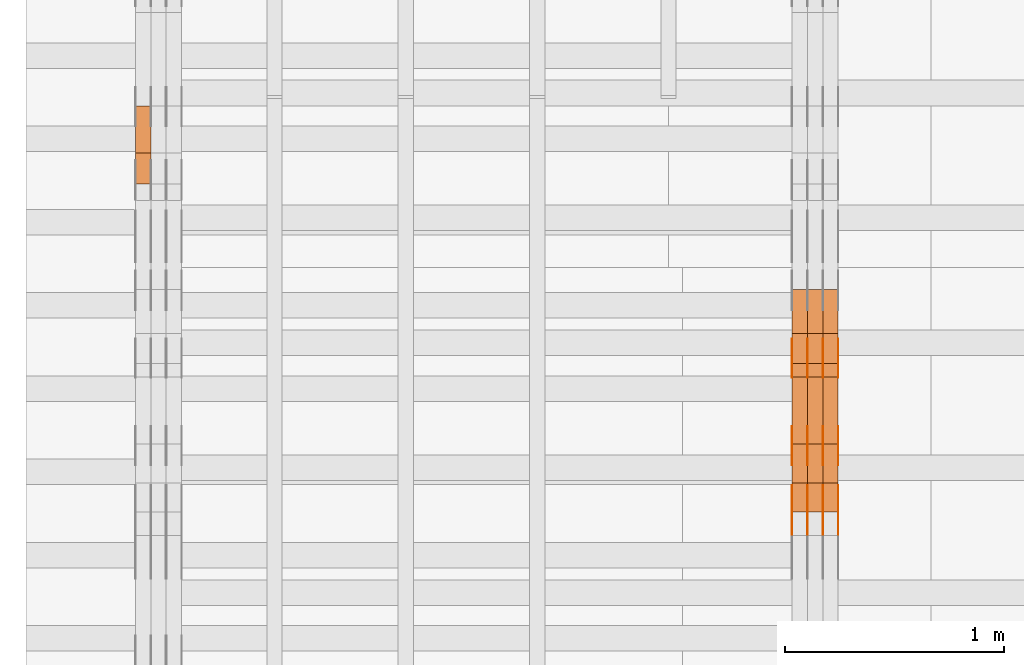
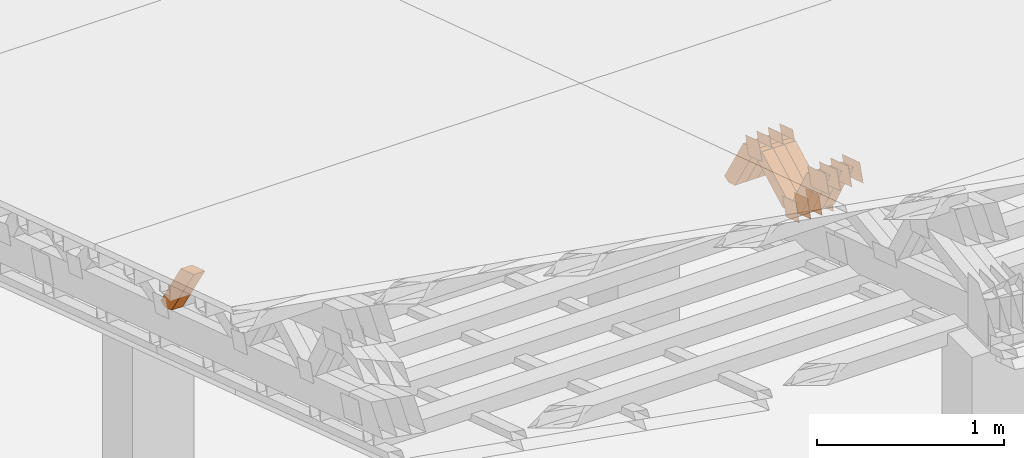
# One storey, part 172 of 385: 28 proxies.
"""IFC2X3 building model written with IfcOpenShell, lengths in millimetres."""

from ifc_helpers import new_model, entity, si_unit, converted_unit, derived_unit, direction, frame, origin, place, context, subcontext, project, spatial, polyline, outline, extrude, source, transform, mapped, material, type_object, type_shapes, element, save


model = new_model("IFC2X3")

# Units and contexts
model_context = context("Model", 3, precision=0.01, world=origin(), true_north=direction((6.12303176911189e-17, 1.0)))
body_context = subcontext(model_context, "Body", "Model", "MODEL_VIEW")
ifc_project = project(units=[si_unit("LENGTHUNIT", "METRE", prefix="MILLI"), si_unit("AREAUNIT", "SQUARE_METRE"), si_unit("VOLUMEUNIT", "CUBIC_METRE"), converted_unit("PLANEANGLEUNIT", "DEGREE", entity("IfcRatioMeasure", 0.0174532925199433), si_unit("PLANEANGLEUNIT", "RADIAN"), dimensions=[0, 0, 0, 0, 0, 0, 0]), si_unit("MASSUNIT", "GRAM", prefix="KILO"), derived_unit("MASSDENSITYUNIT", [(si_unit("MASSUNIT", "GRAM", prefix="KILO"), 1), (si_unit("LENGTHUNIT", "METRE"), -3)]), si_unit("TIMEUNIT", "SECOND"), si_unit("FREQUENCYUNIT", "HERTZ"), si_unit("THERMODYNAMICTEMPERATUREUNIT", "DEGREE_CELSIUS"), derived_unit("THERMALTRANSMITTANCEUNIT", [(si_unit("MASSUNIT", "GRAM", prefix="KILO"), 1), (si_unit("THERMODYNAMICTEMPERATUREUNIT", "KELVIN"), -1), (si_unit("TIMEUNIT", "SECOND"), -3)]), derived_unit("VOLUMETRICFLOWRATEUNIT", [(si_unit("LENGTHUNIT", "METRE"), 3), (si_unit("TIMEUNIT", "SECOND"), -1)]), si_unit("ELECTRICCURRENTUNIT", "AMPERE"), si_unit("ELECTRICVOLTAGEUNIT", "VOLT"), si_unit("POWERUNIT", "WATT"), si_unit("FORCEUNIT", "NEWTON", prefix="KILO"), si_unit("ILLUMINANCEUNIT", "LUX"), si_unit("LUMINOUSFLUXUNIT", "LUMEN"), si_unit("LUMINOUSINTENSITYUNIT", "CANDELA"), derived_unit("USERDEFINED", [(si_unit("MASSUNIT", "GRAM", prefix="KILO"), -1), (si_unit("LENGTHUNIT", "METRE"), -2), (si_unit("TIMEUNIT", "SECOND"), 3), (si_unit("LUMINOUSFLUXUNIT", "LUMEN"), 1)]), derived_unit("LINEARVELOCITYUNIT", [(si_unit("LENGTHUNIT", "METRE"), 1), (si_unit("TIMEUNIT", "SECOND"), -1)]), si_unit("PRESSUREUNIT", "PASCAL"), derived_unit("USERDEFINED", [(si_unit("LENGTHUNIT", "METRE"), -2), (si_unit("MASSUNIT", "GRAM", prefix="KILO"), 1), (si_unit("TIMEUNIT", "SECOND"), -2)])], contexts=[model_context])

# Site, building, storey
site_placement = place(None, origin())
site = spatial("IfcSite", under=ifc_project, at=site_placement, CompositionType="ELEMENT")
building_placement = place(site_placement, origin())
building = spatial("IfcBuilding", under=site, at=building_placement, CompositionType="ELEMENT")
storey_placement = place(building_placement, origin())
storey = spatial("IfcBuildingStorey", under=building, at=storey_placement, Name="Default", CompositionType="ELEMENT", Elevation=0.0)

# Proxies
ifc_material_1 = material(Name="IfcSurfaceStyle #73122")
building_element_proxy_type_1 = type_object("IfcBuildingElementProxyType", PredefinedType="NOTDEFINED", material=ifc_material_1)
shared_shape_1 = source(origin(), body_context, "Body", "SweptSolid", [
    extrude(outline(polyline([(-74.9998982809088, -60.000042563519), (74.9998377068237, -60.000042563519), (74.9998982809079, 60.0000425635189), (-74.9998377068227, 60.0000425635189), (-74.9998982809088, -60.000042563519)])), frame((75.0001050385304, 60.0001177331169, 0.0), z_axis=(0.0, 0.0, 1.0), x_axis=(-1.0, 0.0, 0.0)), (0.0, 0.0, 1.0), 1.3),
])
type_shapes(building_element_proxy_type_1, [shared_shape_1])
proxy_1_placement = place(building_placement, frame((3386.29999999999, 19806.7306653882, 2506.65203571776), z_axis=(-1.0, 0.0, 0.0), x_axis=(0.0, -0.951056516295154, 0.309016994374948)))
element("IfcBuildingElementProxy", 1, at=proxy_1_placement, inside=storey, type_object=building_element_proxy_type_1, material=ifc_material_1, context=body_context, shape_type="MappedRepresentation", body=[
    mapped(shared_shape_1, transform((0.0, 0.0, 0.0), scale=1.0)),
])
ifc_material_2 = material(Name="IfcSurfaceStyle #73065")
building_element_proxy_type_2 = type_object("IfcBuildingElementProxyType", PredefinedType="NOTDEFINED", material=ifc_material_2)
shared_shape_2 = source(origin(), body_context, "Body", "SweptSolid", [
    extrude(outline(polyline([(-74.9998982809088, -60.000042563519), (74.9998377068237, -60.000042563519), (74.9998982809079, 60.0000425635189), (-74.9998377068227, 60.0000425635189), (-74.9998982809088, -60.000042563519)])), frame((75.0001050385304, 60.0001177331169, 0.0), z_axis=(0.0, 0.0, 1.0), x_axis=(-1.0, 0.0, 0.0)), (0.0, 0.0, 1.0), 1.3),
])
type_shapes(building_element_proxy_type_2, [shared_shape_2])
proxy_2_placement = place(building_placement, frame((3315.0, 19806.7306653882, 2506.65203571776), z_axis=(-1.0, 0.0, 0.0), x_axis=(0.0, -0.951056516295154, 0.309016994374948)))
element("IfcBuildingElementProxy", 2, at=proxy_2_placement, inside=storey, type_object=building_element_proxy_type_2, material=ifc_material_2, context=body_context, shape_type="MappedRepresentation", body=[
    mapped(shared_shape_2, transform((0.0, 0.0, 0.0), scale=1.0)),
])
ifc_material_3 = material(Name="IfcSurfaceStyle #73008")
building_element_proxy_type_3 = type_object("IfcBuildingElementProxyType", PredefinedType="NOTDEFINED", material=ifc_material_3)
shared_shape_3 = source(origin(), body_context, "Body", "SweptSolid", [
    extrude(outline(polyline([(-74.9998982809088, -60.000042563519), (74.9998377068237, -60.000042563519), (74.9998982809079, 60.0000425635189), (-74.9998377068227, 60.0000425635189), (-74.9998982809088, -60.000042563519)])), frame((75.0001050385304, 60.0001177331169, 0.0), z_axis=(0.0, 0.0, 1.0), x_axis=(-1.0, 0.0, 0.0)), (0.0, 0.0, 1.0), 1.3),
])
type_shapes(building_element_proxy_type_3, [shared_shape_3])
proxy_3_placement = place(building_placement, frame((3316.29999999999, 19806.7306653882, 2506.65203571776), z_axis=(-1.0, 0.0, 0.0), x_axis=(0.0, -0.951056516295154, 0.309016994374948)))
element("IfcBuildingElementProxy", 3, at=proxy_3_placement, inside=storey, type_object=building_element_proxy_type_3, material=ifc_material_3, context=body_context, shape_type="MappedRepresentation", body=[
    mapped(shared_shape_3, transform((0.0, 0.0, 0.0), scale=1.0)),
])
ifc_material_4 = material(Name="IfcSurfaceStyle #72951")
building_element_proxy_type_4 = type_object("IfcBuildingElementProxyType", PredefinedType="NOTDEFINED", material=ifc_material_4)
shared_shape_4 = source(origin(), body_context, "Body", "SweptSolid", [
    extrude(outline(polyline([(-74.9998982809088, -60.000042563519), (74.9998377068237, -60.000042563519), (74.9998982809079, 60.0000425635189), (-74.9998377068227, 60.0000425635189), (-74.9998982809088, -60.000042563519)])), frame((75.0001050385304, 60.0001177331169, 0.0), z_axis=(0.0, 0.0, 1.0), x_axis=(-1.0, 0.0, 0.0)), (0.0, 0.0, 1.0), 1.29999999999999),
])
type_shapes(building_element_proxy_type_4, [shared_shape_4])
proxy_4_placement = place(building_placement, frame((3245.0, 19806.7306653882, 2506.65203571776), z_axis=(-1.0, 0.0, 0.0), x_axis=(0.0, -0.951056516295154, 0.309016994374948)))
element("IfcBuildingElementProxy", 4, at=proxy_4_placement, inside=storey, type_object=building_element_proxy_type_4, material=ifc_material_4, context=body_context, shape_type="MappedRepresentation", body=[
    mapped(shared_shape_4, transform((0.0, 0.0, 0.0), scale=1.0)),
])
ifc_material_5 = material(Name="IfcSurfaceStyle #72894")
building_element_proxy_type_5 = type_object("IfcBuildingElementProxyType", PredefinedType="NOTDEFINED", material=ifc_material_5)
shared_shape_5 = source(origin(), body_context, "Body", "SweptSolid", [
    extrude(outline(polyline([(-74.9998982809088, -60.000042563519), (74.9998377068237, -60.000042563519), (74.9998982809079, 60.0000425635189), (-74.9998377068227, 60.0000425635189), (-74.9998982809088, -60.000042563519)])), frame((75.0001050385304, 60.0001177331169, 0.0), z_axis=(0.0, 0.0, 1.0), x_axis=(-1.0, 0.0, 0.0)), (0.0, 0.0, 1.0), 1.29999999999999),
])
type_shapes(building_element_proxy_type_5, [shared_shape_5])
proxy_5_placement = place(building_placement, frame((3246.29999999999, 19806.7306653882, 2506.65203571776), z_axis=(-1.0, 0.0, 0.0), x_axis=(0.0, -0.951056516295154, 0.309016994374948)))
element("IfcBuildingElementProxy", 5, at=proxy_5_placement, inside=storey, type_object=building_element_proxy_type_5, material=ifc_material_5, context=body_context, shape_type="MappedRepresentation", body=[
    mapped(shared_shape_5, transform((0.0, 0.0, 0.0), scale=1.0)),
])
ifc_material_6 = material(Name="IfcSurfaceStyle #72837")
building_element_proxy_type_6 = type_object("IfcBuildingElementProxyType", PredefinedType="NOTDEFINED", material=ifc_material_6)
shared_shape_6 = source(origin(), body_context, "Body", "SweptSolid", [
    extrude(outline(polyline([(-74.9998982809088, -60.000042563519), (74.9998377068237, -60.000042563519), (74.9998982809079, 60.0000425635189), (-74.9998377068227, 60.0000425635189), (-74.9998982809088, -60.000042563519)])), frame((75.0001050385304, 60.0001177331169, 0.0), z_axis=(0.0, 0.0, 1.0), x_axis=(-1.0, 0.0, 0.0)), (0.0, 0.0, 1.0), 1.29999999999999),
])
type_shapes(building_element_proxy_type_6, [shared_shape_6])
proxy_6_placement = place(building_placement, frame((3175.0, 19806.7306653882, 2506.65203571776), z_axis=(-1.0, 0.0, 0.0), x_axis=(0.0, -0.951056516295154, 0.309016994374948)))
element("IfcBuildingElementProxy", 6, at=proxy_6_placement, inside=storey, type_object=building_element_proxy_type_6, material=ifc_material_6, context=body_context, shape_type="MappedRepresentation", body=[
    mapped(shared_shape_6, transform((0.0, 0.0, 0.0), scale=1.0)),
])
ifc_material_7 = material(Name="IfcSurfaceStyle #71754")
building_element_proxy_type_7 = type_object("IfcBuildingElementProxyType", PredefinedType="NOTDEFINED", material=ifc_material_7)
shared_shape_7 = source(origin(), body_context, "Body", "SweptSolid", [
    extrude(outline(polyline([(-99.9998479918963, -59.9999913366637), (99.9998251396114, -59.9999913366637), (99.9998102700952, 59.9999913366637), (-99.9997874178102, 59.9999913366637), (-99.9998479918963, -59.9999913366637)])), frame((99.9998251396114, 60.0000609537942, 0.0), z_axis=(0.0, 0.0, 1.0), x_axis=(-1.0, 0.0, 0.0)), (0.0, 0.0, 1.0), 1.3),
])
type_shapes(building_element_proxy_type_7, [shared_shape_7])
proxy_7_placement = place(building_placement, frame((3386.29999999999, 19136.9072023289, 2711.67346128215), z_axis=(-1.0, 0.0, 0.0), x_axis=(0.0, -0.951056516295154, 0.309016994374948)))
element("IfcBuildingElementProxy", 7, at=proxy_7_placement, inside=storey, type_object=building_element_proxy_type_7, material=ifc_material_7, context=body_context, shape_type="MappedRepresentation", body=[
    mapped(shared_shape_7, transform((0.0, 0.0, 0.0), scale=1.0)),
])
ifc_material_8 = material(Name="IfcSurfaceStyle #71697")
building_element_proxy_type_8 = type_object("IfcBuildingElementProxyType", PredefinedType="NOTDEFINED", material=ifc_material_8)
shared_shape_8 = source(origin(), body_context, "Body", "SweptSolid", [
    extrude(outline(polyline([(-99.9998479918963, -59.9999913366637), (99.9998251396114, -59.9999913366637), (99.9998102700952, 59.9999913366637), (-99.9997874178102, 59.9999913366637), (-99.9998479918963, -59.9999913366637)])), frame((99.9998251396114, 60.0000609537942, 0.0), z_axis=(0.0, 0.0, 1.0), x_axis=(-1.0, 0.0, 0.0)), (0.0, 0.0, 1.0), 1.3),
])
type_shapes(building_element_proxy_type_8, [shared_shape_8])
proxy_8_placement = place(building_placement, frame((3315.0, 19136.9072023289, 2711.67346128215), z_axis=(-1.0, 0.0, 0.0), x_axis=(0.0, -0.951056516295154, 0.309016994374948)))
element("IfcBuildingElementProxy", 8, at=proxy_8_placement, inside=storey, type_object=building_element_proxy_type_8, material=ifc_material_8, context=body_context, shape_type="MappedRepresentation", body=[
    mapped(shared_shape_8, transform((0.0, 0.0, 0.0), scale=1.0)),
])
ifc_material_9 = material(Name="IfcSurfaceStyle #71640")
building_element_proxy_type_9 = type_object("IfcBuildingElementProxyType", PredefinedType="NOTDEFINED", material=ifc_material_9)
shared_shape_9 = source(origin(), body_context, "Body", "SweptSolid", [
    extrude(outline(polyline([(-99.9998479918963, -59.9999913366637), (99.9998251396114, -59.9999913366637), (99.9998102700952, 59.9999913366637), (-99.9997874178102, 59.9999913366637), (-99.9998479918963, -59.9999913366637)])), frame((99.9998251396114, 60.0000609537942, 0.0), z_axis=(0.0, 0.0, 1.0), x_axis=(-1.0, 0.0, 0.0)), (0.0, 0.0, 1.0), 1.3),
])
type_shapes(building_element_proxy_type_9, [shared_shape_9])
proxy_9_placement = place(building_placement, frame((3316.29999999999, 19136.9072023289, 2711.67346128215), z_axis=(-1.0, 0.0, 0.0), x_axis=(0.0, -0.951056516295154, 0.309016994374948)))
element("IfcBuildingElementProxy", 9, at=proxy_9_placement, inside=storey, type_object=building_element_proxy_type_9, material=ifc_material_9, context=body_context, shape_type="MappedRepresentation", body=[
    mapped(shared_shape_9, transform((0.0, 0.0, 0.0), scale=1.0)),
])
ifc_material_10 = material(Name="IfcSurfaceStyle #71583")
building_element_proxy_type_10 = type_object("IfcBuildingElementProxyType", PredefinedType="NOTDEFINED", material=ifc_material_10)
shared_shape_10 = source(origin(), body_context, "Body", "SweptSolid", [
    extrude(outline(polyline([(-99.9998479918963, -59.9999913366637), (99.9998251396114, -59.9999913366637), (99.9998102700952, 59.9999913366637), (-99.9997874178102, 59.9999913366637), (-99.9998479918963, -59.9999913366637)])), frame((99.9998251396114, 60.0000609537942, 0.0), z_axis=(0.0, 0.0, 1.0), x_axis=(-1.0, 0.0, 0.0)), (0.0, 0.0, 1.0), 1.29999999999998),
])
type_shapes(building_element_proxy_type_10, [shared_shape_10])
proxy_10_placement = place(building_placement, frame((3245.0, 19136.9072023289, 2711.67346128215), z_axis=(-1.0, 0.0, 0.0), x_axis=(0.0, -0.951056516295154, 0.309016994374948)))
element("IfcBuildingElementProxy", 10, at=proxy_10_placement, inside=storey, type_object=building_element_proxy_type_10, material=ifc_material_10, context=body_context, shape_type="MappedRepresentation", body=[
    mapped(shared_shape_10, transform((0.0, 0.0, 0.0), scale=1.0)),
])
ifc_material_11 = material(Name="IfcSurfaceStyle #71526")
building_element_proxy_type_11 = type_object("IfcBuildingElementProxyType", PredefinedType="NOTDEFINED", material=ifc_material_11)
shared_shape_11 = source(origin(), body_context, "Body", "SweptSolid", [
    extrude(outline(polyline([(-99.9998479918963, -59.9999913366637), (99.9998251396114, -59.9999913366637), (99.9998102700952, 59.9999913366637), (-99.9997874178102, 59.9999913366637), (-99.9998479918963, -59.9999913366637)])), frame((99.9998251396114, 60.0000609537942, 0.0), z_axis=(0.0, 0.0, 1.0), x_axis=(-1.0, 0.0, 0.0)), (0.0, 0.0, 1.0), 1.29999999999998),
])
type_shapes(building_element_proxy_type_11, [shared_shape_11])
proxy_11_placement = place(building_placement, frame((3246.29999999999, 19136.9072023289, 2711.67346128215), z_axis=(-1.0, 0.0, 0.0), x_axis=(0.0, -0.951056516295154, 0.309016994374948)))
element("IfcBuildingElementProxy", 11, at=proxy_11_placement, inside=storey, type_object=building_element_proxy_type_11, material=ifc_material_11, context=body_context, shape_type="MappedRepresentation", body=[
    mapped(shared_shape_11, transform((0.0, 0.0, 0.0), scale=1.0)),
])
ifc_material_12 = material(Name="IfcSurfaceStyle #71469")
building_element_proxy_type_12 = type_object("IfcBuildingElementProxyType", PredefinedType="NOTDEFINED", material=ifc_material_12)
shared_shape_12 = source(origin(), body_context, "Body", "SweptSolid", [
    extrude(outline(polyline([(-99.9998479918963, -59.9999913366637), (99.9998251396114, -59.9999913366637), (99.9998102700952, 59.9999913366637), (-99.9997874178102, 59.9999913366637), (-99.9998479918963, -59.9999913366637)])), frame((99.9998251396114, 60.0000609537942, 0.0), z_axis=(0.0, 0.0, 1.0), x_axis=(-1.0, 0.0, 0.0)), (0.0, 0.0, 1.0), 1.29999999999999),
])
type_shapes(building_element_proxy_type_12, [shared_shape_12])
proxy_12_placement = place(building_placement, frame((3175.0, 19136.9072023289, 2711.67346128215), z_axis=(-1.0, 0.0, 0.0), x_axis=(0.0, -0.951056516295154, 0.309016994374948)))
element("IfcBuildingElementProxy", 12, at=proxy_12_placement, inside=storey, type_object=building_element_proxy_type_12, material=ifc_material_12, context=body_context, shape_type="MappedRepresentation", body=[
    mapped(shared_shape_12, transform((0.0, 0.0, 0.0), scale=1.0)),
])
ifc_material_13 = material(Name="IfcSurfaceStyle #66624")
building_element_proxy_type_13 = type_object("IfcBuildingElementProxyType", PredefinedType="NOTDEFINED", material=ifc_material_13)
shared_shape_13 = source(origin(), body_context, "Body", "SweptSolid", [
    extrude(outline(polyline([(-74.9998605591127, -59.9999264677599), (74.999875428618, -59.9999264677599), (74.9998605591127, 59.9999264677599), (-74.999875428618, 59.9999264677599), (-74.9998605591127, -59.9999264677599)])), frame((75.0002655673825, 60.0000016373433, 0.0), z_axis=(0.0, 0.0, 1.0), x_axis=(-1.0, 0.0, 0.0)), (0.0, 0.0, 1.0), 1.3),
])
type_shapes(building_element_proxy_type_13, [shared_shape_13])
proxy_13_placement = place(building_placement, frame((3386.29999999999, 19407.1136664358, 2348.71056820494), z_axis=(-1.0, 0.0, 0.0), x_axis=(0.0, -0.951056516295124, 0.309016994375039)))
element("IfcBuildingElementProxy", 13, at=proxy_13_placement, inside=storey, type_object=building_element_proxy_type_13, material=ifc_material_13, context=body_context, shape_type="MappedRepresentation", body=[
    mapped(shared_shape_13, transform((0.0, 0.0, 0.0), scale=1.0)),
])
ifc_material_14 = material(Name="IfcSurfaceStyle #66567")
building_element_proxy_type_14 = type_object("IfcBuildingElementProxyType", PredefinedType="NOTDEFINED", material=ifc_material_14)
shared_shape_14 = source(origin(), body_context, "Body", "SweptSolid", [
    extrude(outline(polyline([(-74.9998605591127, -59.9999264677599), (74.999875428618, -59.9999264677599), (74.9998605591127, 59.9999264677599), (-74.999875428618, 59.9999264677599), (-74.9998605591127, -59.9999264677599)])), frame((75.0002655673825, 60.0000016373433, 0.0), z_axis=(0.0, 0.0, 1.0), x_axis=(-1.0, 0.0, 0.0)), (0.0, 0.0, 1.0), 1.3),
])
type_shapes(building_element_proxy_type_14, [shared_shape_14])
proxy_14_placement = place(building_placement, frame((3315.0, 19407.1136664358, 2348.71056820494), z_axis=(-1.0, 0.0, 0.0), x_axis=(0.0, -0.951056516295124, 0.309016994375039)))
element("IfcBuildingElementProxy", 14, at=proxy_14_placement, inside=storey, type_object=building_element_proxy_type_14, material=ifc_material_14, context=body_context, shape_type="MappedRepresentation", body=[
    mapped(shared_shape_14, transform((0.0, 0.0, 0.0), scale=1.0)),
])
ifc_material_15 = material(Name="IfcSurfaceStyle #66510")
building_element_proxy_type_15 = type_object("IfcBuildingElementProxyType", PredefinedType="NOTDEFINED", material=ifc_material_15)
shared_shape_15 = source(origin(), body_context, "Body", "SweptSolid", [
    extrude(outline(polyline([(-74.9998605591127, -59.9999264677599), (74.999875428618, -59.9999264677599), (74.9998605591127, 59.9999264677599), (-74.999875428618, 59.9999264677599), (-74.9998605591127, -59.9999264677599)])), frame((75.0002655673825, 60.0000016373433, 0.0), z_axis=(0.0, 0.0, 1.0), x_axis=(-1.0, 0.0, 0.0)), (0.0, 0.0, 1.0), 1.3),
])
type_shapes(building_element_proxy_type_15, [shared_shape_15])
proxy_15_placement = place(building_placement, frame((3316.29999999999, 19407.1136664358, 2348.71056820494), z_axis=(-1.0, 0.0, 0.0), x_axis=(0.0, -0.951056516295124, 0.309016994375039)))
element("IfcBuildingElementProxy", 15, at=proxy_15_placement, inside=storey, type_object=building_element_proxy_type_15, material=ifc_material_15, context=body_context, shape_type="MappedRepresentation", body=[
    mapped(shared_shape_15, transform((0.0, 0.0, 0.0), scale=1.0)),
])
ifc_material_16 = material(Name="IfcSurfaceStyle #66453")
building_element_proxy_type_16 = type_object("IfcBuildingElementProxyType", PredefinedType="NOTDEFINED", material=ifc_material_16)
shared_shape_16 = source(origin(), body_context, "Body", "SweptSolid", [
    extrude(outline(polyline([(-74.9998605591127, -59.9999264677599), (74.999875428618, -59.9999264677599), (74.9998605591127, 59.9999264677599), (-74.999875428618, 59.9999264677599), (-74.9998605591127, -59.9999264677599)])), frame((75.0002655673825, 60.0000016373433, 0.0), z_axis=(0.0, 0.0, 1.0), x_axis=(-1.0, 0.0, 0.0)), (0.0, 0.0, 1.0), 1.29999999999999),
])
type_shapes(building_element_proxy_type_16, [shared_shape_16])
proxy_16_placement = place(building_placement, frame((3245.0, 19407.1136664358, 2348.71056820494), z_axis=(-1.0, 0.0, 0.0), x_axis=(0.0, -0.951056516295124, 0.309016994375039)))
element("IfcBuildingElementProxy", 16, at=proxy_16_placement, inside=storey, type_object=building_element_proxy_type_16, material=ifc_material_16, context=body_context, shape_type="MappedRepresentation", body=[
    mapped(shared_shape_16, transform((0.0, 0.0, 0.0), scale=1.0)),
])
ifc_material_17 = material(Name="IfcSurfaceStyle #66396")
building_element_proxy_type_17 = type_object("IfcBuildingElementProxyType", PredefinedType="NOTDEFINED", material=ifc_material_17)
shared_shape_17 = source(origin(), body_context, "Body", "SweptSolid", [
    extrude(outline(polyline([(-74.9998605591127, -59.9999264677599), (74.999875428618, -59.9999264677599), (74.9998605591127, 59.9999264677599), (-74.999875428618, 59.9999264677599), (-74.9998605591127, -59.9999264677599)])), frame((75.0002655673825, 60.0000016373433, 0.0), z_axis=(0.0, 0.0, 1.0), x_axis=(-1.0, 0.0, 0.0)), (0.0, 0.0, 1.0), 1.29999999999999),
])
type_shapes(building_element_proxy_type_17, [shared_shape_17])
proxy_17_placement = place(building_placement, frame((3246.29999999999, 19407.1136664358, 2348.71056820494), z_axis=(-1.0, 0.0, 0.0), x_axis=(0.0, -0.951056516295124, 0.309016994375039)))
element("IfcBuildingElementProxy", 17, at=proxy_17_placement, inside=storey, type_object=building_element_proxy_type_17, material=ifc_material_17, context=body_context, shape_type="MappedRepresentation", body=[
    mapped(shared_shape_17, transform((0.0, 0.0, 0.0), scale=1.0)),
])
ifc_material_18 = material(Name="IfcSurfaceStyle #66339")
building_element_proxy_type_18 = type_object("IfcBuildingElementProxyType", PredefinedType="NOTDEFINED", material=ifc_material_18)
shared_shape_18 = source(origin(), body_context, "Body", "SweptSolid", [
    extrude(outline(polyline([(-74.9998605591127, -59.9999264677599), (74.999875428618, -59.9999264677599), (74.9998605591127, 59.9999264677599), (-74.999875428618, 59.9999264677599), (-74.9998605591127, -59.9999264677599)])), frame((75.0002655673825, 60.0000016373433, 0.0), z_axis=(0.0, 0.0, 1.0), x_axis=(-1.0, 0.0, 0.0)), (0.0, 0.0, 1.0), 1.29999999999999),
])
type_shapes(building_element_proxy_type_18, [shared_shape_18])
proxy_18_placement = place(building_placement, frame((3175.0, 19407.1136664358, 2348.71056820494), z_axis=(-1.0, 0.0, 0.0), x_axis=(0.0, -0.951056516295124, 0.309016994375039)))
element("IfcBuildingElementProxy", 18, at=proxy_18_placement, inside=storey, type_object=building_element_proxy_type_18, material=ifc_material_18, context=body_context, shape_type="MappedRepresentation", body=[
    mapped(shared_shape_18, transform((0.0, 0.0, 0.0), scale=1.0)),
])
ifc_material_19 = material(Name="IfcSurfaceStyle #49866")
building_element_proxy_type_19 = type_object("IfcBuildingElementProxyType", Name="T1-W40 49864", PredefinedType="NOTDEFINED", material=ifc_material_19)
shared_shape_19 = source(origin(), body_context, "Body", "SweptSolid", [
    extrude(outline(polyline([(-190.697067347251, -47.4992767218045), (178.704677543904, -47.4992767218045), (178.119540532346, -0.000296092407564622), (126.935785980356, 47.4999913795318), (-293.062936709355, 47.4988581564849), (-190.697067347251, -47.4992767218045)])), frame((178.7049897723, 47.4999913795318, 0.0), z_axis=(0.0, 0.0, 1.0), x_axis=(-1.0, 0.0, 0.0)), (0.0, 0.0, 1.0), 70.0),
])
type_shapes(building_element_proxy_type_19, [shared_shape_19])
proxy_19_placement = place(building_placement, frame((3385.0, 19280.269490882, 2403.36730959494), z_axis=(-1.0, 0.0, 0.0), x_axis=(0.0, -0.48691092455798, 0.873451630913866)))
element("IfcBuildingElementProxy", 19, at=proxy_19_placement, inside=storey, type_object=building_element_proxy_type_19, material=ifc_material_19, Name="T1-W40", context=body_context, shape_type="MappedRepresentation", body=[
    mapped(shared_shape_19, transform((0.0, 0.0, 0.0), scale=1.0)),
])
ifc_material_20 = material(Name="IfcSurfaceStyle #49800")
building_element_proxy_type_20 = type_object("IfcBuildingElementProxyType", Name="T1-W40 49798", PredefinedType="NOTDEFINED", material=ifc_material_20)
shared_shape_20 = source(origin(), body_context, "Body", "SweptSolid", [
    extrude(outline(polyline([(-190.697067347251, -47.4992767218045), (178.704677543904, -47.4992767218045), (178.119540532346, -0.000296092407564622), (126.935785980356, 47.4999913795318), (-293.062936709355, 47.4988581564849), (-190.697067347251, -47.4992767218045)])), frame((178.7049897723, 47.4999913795318, 0.0), z_axis=(0.0, 0.0, 1.0), x_axis=(-1.0, 0.0, 0.0)), (0.0, 0.0, 1.0), 70.0),
])
type_shapes(building_element_proxy_type_20, [shared_shape_20])
proxy_20_placement = place(building_placement, frame((3315.0, 19280.269490882, 2403.36730959494), z_axis=(-1.0, 0.0, 0.0), x_axis=(0.0, -0.48691092455798, 0.873451630913866)))
element("IfcBuildingElementProxy", 20, at=proxy_20_placement, inside=storey, type_object=building_element_proxy_type_20, material=ifc_material_20, Name="T1-W40", context=body_context, shape_type="MappedRepresentation", body=[
    mapped(shared_shape_20, transform((0.0, 0.0, 0.0), scale=1.0)),
])
ifc_material_21 = material(Name="IfcSurfaceStyle #49734")
building_element_proxy_type_21 = type_object("IfcBuildingElementProxyType", Name="T1-W40 49732", PredefinedType="NOTDEFINED", material=ifc_material_21)
shared_shape_21 = source(origin(), body_context, "Body", "SweptSolid", [
    extrude(outline(polyline([(-190.697067347251, -47.4992767218045), (178.704677543904, -47.4992767218045), (178.119540532346, -0.000296092407564622), (126.935785980356, 47.4999913795318), (-293.062936709355, 47.4988581564849), (-190.697067347251, -47.4992767218045)])), frame((178.7049897723, 47.4999913795318, 0.0), z_axis=(0.0, 0.0, 1.0), x_axis=(-1.0, 0.0, 0.0)), (0.0, 0.0, 1.0), 70.0),
])
type_shapes(building_element_proxy_type_21, [shared_shape_21])
proxy_21_placement = place(building_placement, frame((3245.0, 19280.269490882, 2403.36730959494), z_axis=(-1.0, 0.0, 0.0), x_axis=(0.0, -0.48691092455798, 0.873451630913866)))
element("IfcBuildingElementProxy", 21, at=proxy_21_placement, inside=storey, type_object=building_element_proxy_type_21, material=ifc_material_21, Name="T1-W40", context=body_context, shape_type="MappedRepresentation", body=[
    mapped(shared_shape_21, transform((0.0, 0.0, 0.0), scale=1.0)),
])
ifc_material_22 = material(Name="IfcSurfaceStyle #49470")
building_element_proxy_type_22 = type_object("IfcBuildingElementProxyType", Name="T1-W47 49468", PredefinedType="NOTDEFINED", material=ifc_material_22)
shared_shape_22 = source(origin(), body_context, "Body", "SweptSolid", [
    extrude(outline(polyline([(-273.154581805017, -47.5000119135351), (121.157675769026, -47.5000119135351), (166.341960897813, -0.000128144957132403), (168.441931699108, 47.5000759860137), (-182.78698656093, 47.5000759860137), (-273.154581805017, -47.5000119135351)])), frame((168.441931699108, 47.5000759860137, 0.0), z_axis=(0.0, 0.0, 1.0), x_axis=(-1.0, 0.0, 0.0)), (0.0, 0.0, 1.0), 70.0),
])
type_shapes(building_element_proxy_type_22, [shared_shape_22])
proxy_22_placement = place(building_placement, frame((3385.0, 19755.0380859375, 2553.712890625), z_axis=(-1.0, 0.0, 0.0), x_axis=(0.0, -0.879386813332609, -0.476108005117242)))
element("IfcBuildingElementProxy", 22, at=proxy_22_placement, inside=storey, type_object=building_element_proxy_type_22, material=ifc_material_22, Name="T1-W47", context=body_context, shape_type="MappedRepresentation", body=[
    mapped(shared_shape_22, transform((0.0, 0.0, 0.0), scale=1.0)),
])
ifc_material_23 = material(Name="IfcSurfaceStyle #49404")
building_element_proxy_type_23 = type_object("IfcBuildingElementProxyType", Name="T1-W47 49402", PredefinedType="NOTDEFINED", material=ifc_material_23)
shared_shape_23 = source(origin(), body_context, "Body", "SweptSolid", [
    extrude(outline(polyline([(-273.154581805017, -47.5000119135351), (121.157675769026, -47.5000119135351), (166.341960897813, -0.000128144957132403), (168.441931699108, 47.5000759860137), (-182.78698656093, 47.5000759860137), (-273.154581805017, -47.5000119135351)])), frame((168.441931699108, 47.5000759860137, 0.0), z_axis=(0.0, 0.0, 1.0), x_axis=(-1.0, 0.0, 0.0)), (0.0, 0.0, 1.0), 70.0),
])
type_shapes(building_element_proxy_type_23, [shared_shape_23])
proxy_23_placement = place(building_placement, frame((3315.0, 19755.0380859375, 2553.712890625), z_axis=(-1.0, 0.0, 0.0), x_axis=(0.0, -0.879386813332609, -0.476108005117242)))
element("IfcBuildingElementProxy", 23, at=proxy_23_placement, inside=storey, type_object=building_element_proxy_type_23, material=ifc_material_23, Name="T1-W47", context=body_context, shape_type="MappedRepresentation", body=[
    mapped(shared_shape_23, transform((0.0, 0.0, 0.0), scale=1.0)),
])
ifc_material_24 = material(Name="IfcSurfaceStyle #49338")
building_element_proxy_type_24 = type_object("IfcBuildingElementProxyType", Name="T1-W47 49336", PredefinedType="NOTDEFINED", material=ifc_material_24)
shared_shape_24 = source(origin(), body_context, "Body", "SweptSolid", [
    extrude(outline(polyline([(-273.154581805017, -47.5000119135351), (121.157675769026, -47.5000119135351), (166.341960897813, -0.000128144957132403), (168.441931699108, 47.5000759860137), (-182.78698656093, 47.5000759860137), (-273.154581805017, -47.5000119135351)])), frame((168.441931699108, 47.5000759860137, 0.0), z_axis=(0.0, 0.0, 1.0), x_axis=(-1.0, 0.0, 0.0)), (0.0, 0.0, 1.0), 70.0),
])
type_shapes(building_element_proxy_type_24, [shared_shape_24])
proxy_24_placement = place(building_placement, frame((3245.0, 19755.0380859375, 2553.712890625), z_axis=(-1.0, 0.0, 0.0), x_axis=(0.0, -0.879386813332609, -0.476108005117242)))
element("IfcBuildingElementProxy", 24, at=proxy_24_placement, inside=storey, type_object=building_element_proxy_type_24, material=ifc_material_24, Name="T1-W47", context=body_context, shape_type="MappedRepresentation", body=[
    mapped(shared_shape_24, transform((0.0, 0.0, 0.0), scale=1.0)),
])
ifc_material_25 = material(Name="IfcSurfaceStyle #49074")
building_element_proxy_type_25 = type_object("IfcBuildingElementProxyType", Name="T1-W34 49072", PredefinedType="NOTDEFINED", material=ifc_material_25)
shared_shape_25 = source(origin(), body_context, "Body", "SweptSolid", [
    extrude(outline(polyline([(-197.657161937088, -47.499796538607), (193.17680883218, -47.499796538607), (182.92464491562, -1.98968224184526e-05), (128.354123102956, 47.4998064870182), (-306.798414913668, 47.4998064870182), (-197.657161937088, -47.499796538607)])), frame((193.176852028916, 47.4998566383869, 0.0), z_axis=(0.0, 0.0, 1.0), x_axis=(-1.0, 0.0, 0.0)), (0.0, 0.0, 1.0), 70.0),
])
type_shapes(building_element_proxy_type_25, [shared_shape_25])
proxy_25_placement = place(building_placement, frame((3385.0, 19987.8030409043, 2165.75390635484), z_axis=(-1.0, 0.0, 0.0), x_axis=(0.0, -0.514479403471631, 0.857502736674044)))
element("IfcBuildingElementProxy", 25, at=proxy_25_placement, inside=storey, type_object=building_element_proxy_type_25, material=ifc_material_25, Name="T1-W34", context=body_context, shape_type="MappedRepresentation", body=[
    mapped(shared_shape_25, transform((0.0, 0.0, 0.0), scale=1.0)),
])
ifc_material_26 = material(Name="IfcSurfaceStyle #49008")
building_element_proxy_type_26 = type_object("IfcBuildingElementProxyType", Name="T1-W34 49006", PredefinedType="NOTDEFINED", material=ifc_material_26)
shared_shape_26 = source(origin(), body_context, "Body", "SweptSolid", [
    extrude(outline(polyline([(-197.657161937088, -47.499796538607), (193.17680883218, -47.499796538607), (182.92464491562, -1.98968224184526e-05), (128.354123102956, 47.4998064870182), (-306.798414913668, 47.4998064870182), (-197.657161937088, -47.499796538607)])), frame((193.176852028916, 47.4998566383869, 0.0), z_axis=(0.0, 0.0, 1.0), x_axis=(-1.0, 0.0, 0.0)), (0.0, 0.0, 1.0), 70.0),
])
type_shapes(building_element_proxy_type_26, [shared_shape_26])
proxy_26_placement = place(building_placement, frame((3315.0, 19987.8030409043, 2165.75390635484), z_axis=(-1.0, 0.0, 0.0), x_axis=(0.0, -0.514479403471631, 0.857502736674044)))
element("IfcBuildingElementProxy", 26, at=proxy_26_placement, inside=storey, type_object=building_element_proxy_type_26, material=ifc_material_26, Name="T1-W34", context=body_context, shape_type="MappedRepresentation", body=[
    mapped(shared_shape_26, transform((0.0, 0.0, 0.0), scale=1.0)),
])
ifc_material_27 = material(Name="IfcSurfaceStyle #48942")
building_element_proxy_type_27 = type_object("IfcBuildingElementProxyType", Name="T1-W34 48940", PredefinedType="NOTDEFINED", material=ifc_material_27)
shared_shape_27 = source(origin(), body_context, "Body", "SweptSolid", [
    extrude(outline(polyline([(-197.657161937088, -47.499796538607), (193.17680883218, -47.499796538607), (182.92464491562, -1.98968224184526e-05), (128.354123102956, 47.4998064870182), (-306.798414913668, 47.4998064870182), (-197.657161937088, -47.499796538607)])), frame((193.176852028916, 47.4998566383869, 0.0), z_axis=(0.0, 0.0, 1.0), x_axis=(-1.0, 0.0, 0.0)), (0.0, 0.0, 1.0), 70.0),
])
type_shapes(building_element_proxy_type_27, [shared_shape_27])
proxy_27_placement = place(building_placement, frame((3245.0, 19987.8030409043, 2165.75390635484), z_axis=(-1.0, 0.0, 0.0), x_axis=(0.0, -0.514479403471631, 0.857502736674044)))
element("IfcBuildingElementProxy", 27, at=proxy_27_placement, inside=storey, type_object=building_element_proxy_type_27, material=ifc_material_27, Name="T1-W34", context=body_context, shape_type="MappedRepresentation", body=[
    mapped(shared_shape_27, transform((0.0, 0.0, 0.0), scale=1.0)),
])
ifc_material_28 = material(Name="IfcSurfaceStyle #13718")
building_element_proxy_type_28 = type_object("IfcBuildingElementProxyType", Name="T1-W29 13716", PredefinedType="NOTDEFINED", material=ifc_material_28)
shared_shape_28 = source(origin(), body_context, "Body", "SweptSolid", [
    extrude(outline(polyline([(-202.325994317059, -47.5000867467013), (200.714255560873, -47.5000867467013), (187.834128885383, 0.000593513395139059), (130.590899902046, 47.4997899900038), (-316.813290031243, 47.4997899900038), (-202.325994317059, -47.5000867467013)])), frame((200.714255560873, 47.5001935424745, 0.0), z_axis=(0.0, 0.0, 1.0), x_axis=(-1.0, 0.0, 0.0)), (0.0, 0.0, 1.0), 70.0),
])
type_shapes(building_element_proxy_type_28, [shared_shape_28])
proxy_28_placement = place(building_placement, frame((245.0, 20827.0771193222, 1890.72342063252), z_axis=(-1.0, 0.0, 0.0), x_axis=(0.0, -0.534567451138397, 0.845125813227473)))
element("IfcBuildingElementProxy", 28, at=proxy_28_placement, inside=storey, type_object=building_element_proxy_type_28, material=ifc_material_28, Name="T1-W29", context=body_context, shape_type="MappedRepresentation", body=[
    mapped(shared_shape_28, transform((0.0, 0.0, 0.0), scale=1.0)),
])

save(model, "model.ifc")
